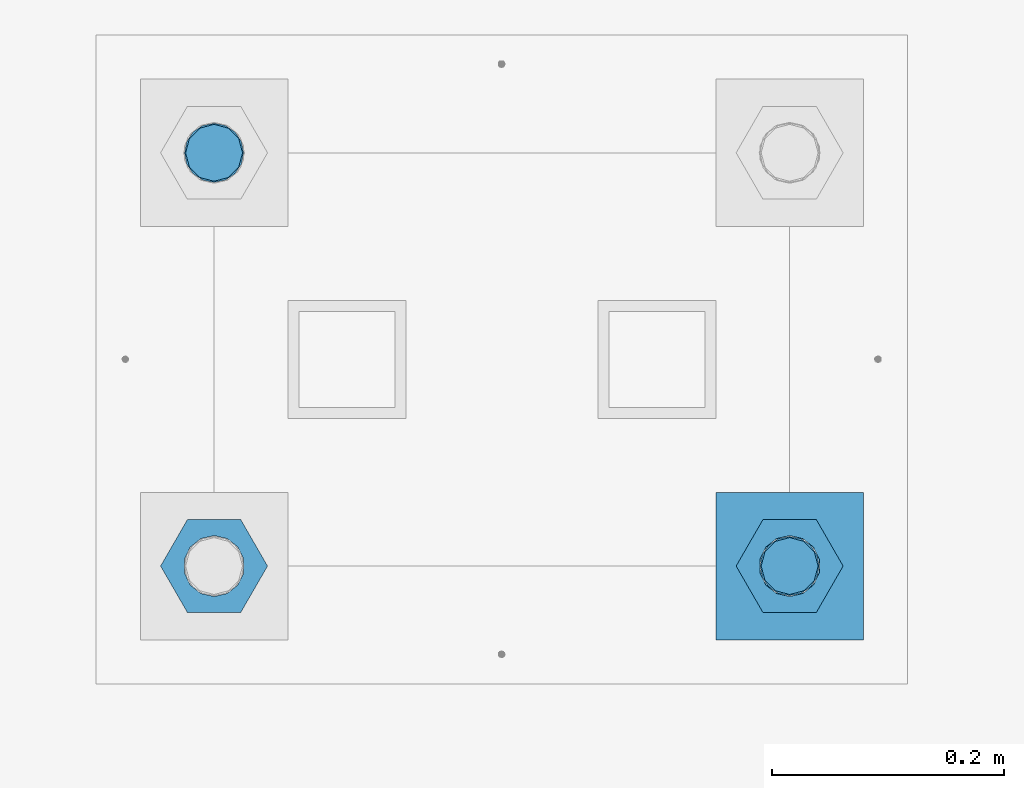
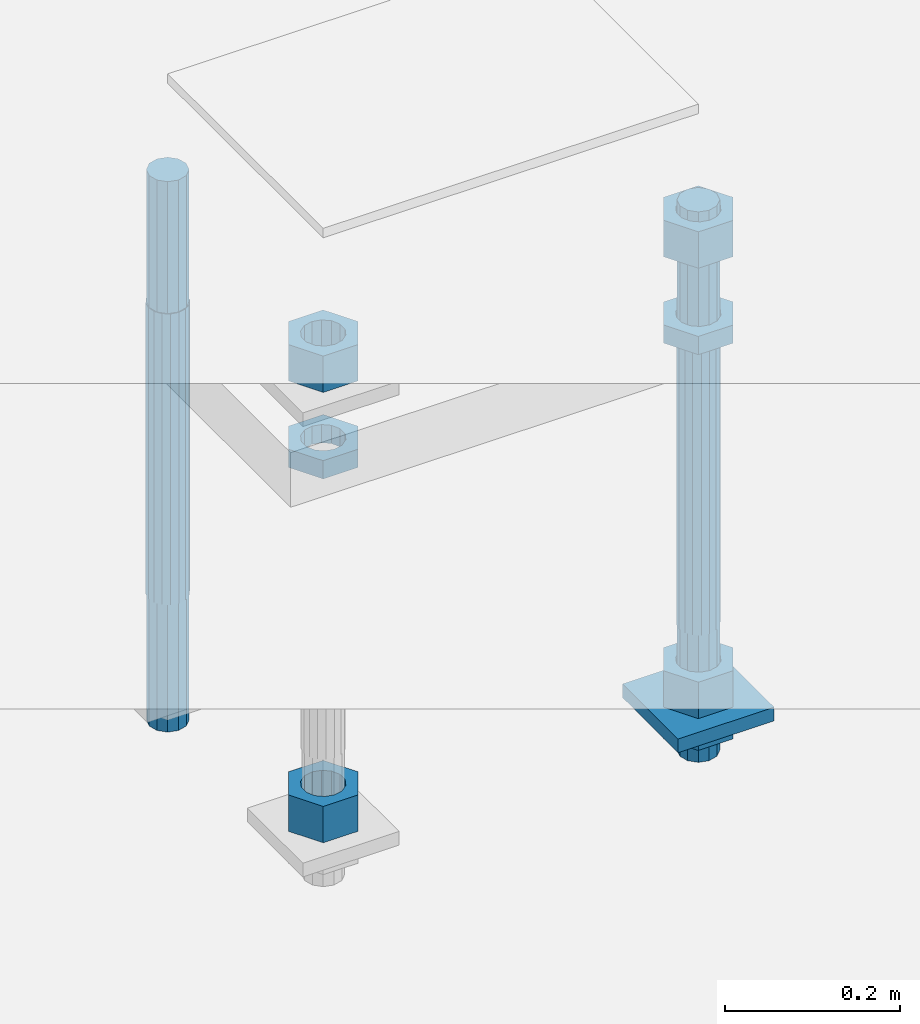
# One storey, part 2571 of 3843: 10 beams, 1 element without a shape of its own.
"""IFC2X3 building model written with IfcOpenShell, lengths in millimetres."""

from ifc_helpers import new_model, si_unit, frame, origin_with_axes, place, context, subcontext, project, spatial, faceted_brep, material, type_object, element, aggregate, save


model = new_model("IFC2X3")

# Units and contexts
model_context = context("Model", 3, precision=1e-05, world=origin_with_axes())
body_context = subcontext(model_context, "Body", "Model", "MODEL_VIEW")
ifc_project = project(units=[si_unit("LENGTHUNIT", "METRE", prefix="MILLI"), si_unit("AREAUNIT", "SQUARE_METRE"), si_unit("VOLUMEUNIT", "CUBIC_METRE"), si_unit("MASSUNIT", "GRAM", prefix="KILO"), si_unit("TIMEUNIT", "SECOND"), si_unit("PLANEANGLEUNIT", "RADIAN"), si_unit("SOLIDANGLEUNIT", "STERADIAN"), si_unit("THERMODYNAMICTEMPERATUREUNIT", "DEGREE_CELSIUS"), si_unit("LUMINOUSINTENSITYUNIT", "LUMEN")], contexts=[model_context])

# Site, building, storey
site_placement = place(None, origin_with_axes())
site = spatial("IfcSite", under=ifc_project, at=site_placement, CompositionType="ELEMENT")
building_placement = place(site_placement, origin_with_axes())
building = spatial("IfcBuilding", under=site, at=building_placement, Name="Undefined", CompositionType="ELEMENT")
storey_placement = place(building_placement, origin_with_axes())
storey = spatial("IfcBuildingStorey", under=building, at=storey_placement, Name="Undefined", CompositionType="ELEMENT", Elevation=0.0)

# Assembly, beams
assembly_placement = place(storey_placement, origin_with_axes())
assembly = element("IfcElementAssembly", 1, at=assembly_placement, inside=storey, Name="TEMPLATE", AssemblyPlace="NOTDEFINED", PredefinedType="RIGID_FRAME")
ifc_material_1 = material(Name="STEEL/A572-50")
beam_type_1 = type_object("IfcBeamType", PredefinedType="NOTDEFINED")
beam_1_placement = place(assembly_placement, frame((105403.65, 7442.19999847412, 29244.925), z_axis=(-1.0, 0.0, 0.0), x_axis=(0.0, -1.0, 0.0)))
beam_1 = element("IfcBeam", 2, at=beam_1_placement, type_object=beam_type_1, material=ifc_material_1, Name="WASHER_PLATE", context=body_context, shape_type="Brep", body=[
    faceted_brep([(0.0, 9.52500000000146, -63.5), (0.0, 9.52500000000146, 63.5), (127.0, 9.52500000000146, 63.5), (127.0, 9.52500000000146, -63.5), (0.0, -9.52500000000146, 63.5), (127.0, -9.52500000000146, 63.5), (0.0, -9.52500000000146, -63.5), (127.0, -9.52500000000146, -63.5)], [[[0, 1, 2, 3]], [[1, 4, 5, 2]], [[4, 6, 7, 5]], [[6, 0, 3, 7]], [[5, 7, 3, 2]], [[6, 4, 1, 0]]]),
])
ifc_material_2 = material(Name="STEEL/A36")
beam_type_2 = type_object("IfcBeamType", Name="2_HALF_NUT", PredefinedType="NOTDEFINED")
beam_2_placement = place(assembly_placement, frame((105403.65, 7378.69999847412, 29787.85), z_axis=(0.0, -1.0, 0.0), x_axis=(0.0, 0.0, -1.0)))
beam_2 = element("IfcBeam", 3, at=beam_2_placement, type_object=beam_type_2, material=ifc_material_2, Name="NUT", ObjectType="2_HALF_NUT", context=body_context, shape_type="Brep", body=[
    faceted_brep([(0.0, -46.0369987487793, 0.0), (0.0, -23.0184993743896, -39.869213104248), (25.4000000000015, -23.0184993743896, -39.869213104248), (25.4000000000015, -46.0369987487793, 0.0), (0.0, 23.0184993743896, -39.869213104248), (25.4000000000015, 23.0184993743896, -39.869213104248), (0.0, 46.0369987487793, 0.0), (25.4000000000015, 46.0369987487793, 0.0), (0.0, 23.0184993743896, 39.869213104248), (25.4000000000015, 23.0184993743896, 39.869213104248), (0.0, -23.0184993743896, 39.869213104248), (25.4000000000015, -23.0184993743896, 39.869213104248), (0.0, 0.0, 26.1940002441406), (0.0, 11.3650617044477, 23.5999013092805), (25.4000000000015, 11.3650617044477, 23.5999013092805), (25.4000000000015, 0.0, 26.1940002441406), (0.0, 20.4791109456419, 16.3316083006721), (25.4000000000015, 20.4791109456419, 16.3316083006721), (0.0, 25.5370200498292, 5.82867859874386), (25.4000000000015, 25.5370200498292, 5.82867859874386), (0.0, 25.5370200498292, -5.82867859874386), (25.4000000000015, 25.5370200498292, -5.82867859874386), (0.0, 20.4791109456419, -16.3316083006721), (25.4000000000015, 20.4791109456419, -16.3316083006721), (0.0, 11.3650617044477, -23.5999013092805), (25.4000000000015, 11.3650617044477, -23.5999013092805), (0.0, 0.0, -26.1940002441406), (25.4000000000015, 0.0, -26.1940002441406), (0.0, -11.3650617044477, -23.5999013092805), (25.4000000000015, -11.3650617044477, -23.5999013092805), (0.0, -20.4791109456419, -16.3316083006721), (25.4000000000015, -20.4791109456419, -16.3316083006721), (0.0, -25.5370200498292, -5.82867859874386), (25.4000000000015, -25.5370200498292, -5.82867859874386), (0.0, -25.5370200498292, 5.82867859874386), (25.4000000000015, -25.5370200498292, 5.82867859874386), (0.0, -20.4791109456419, 16.3316083006721), (25.4000000000015, -20.4791109456419, 16.3316083006721), (0.0, -11.3650617044477, 23.5999013092805), (25.4000000000015, -11.3650617044477, 23.5999013092805)], [[[0, 1, 2, 3]], [[1, 4, 5, 2]], [[4, 6, 7, 5]], [[6, 8, 9, 7]], [[8, 10, 11, 9]], [[10, 0, 3, 11]], [[12, 13, 14, 15]], [[13, 16, 17, 14]], [[16, 18, 19, 17]], [[18, 20, 21, 19]], [[20, 22, 23, 21]], [[22, 24, 25, 23]], [[24, 26, 27, 25]], [[26, 28, 29, 27]], [[28, 30, 31, 29]], [[30, 32, 33, 31]], [[32, 34, 35, 33]], [[34, 36, 37, 35]], [[36, 38, 39, 37]], [[38, 12, 15, 39]], [[5, 7, 9, 11, 3, 2], [17, 19, 21, 23, 25, 27, 29, 31, 33, 35, 37, 39, 15, 14]], [[10, 8, 6, 4, 1, 0], [38, 36, 34, 32, 30, 28, 26, 24, 22, 20, 18, 16, 13, 12]]]),
])
beam_3_placement = place(assembly_placement, frame((105403.65, 7378.69999847412, 29235.4), z_axis=(0.0, -1.0, 0.0), x_axis=(0.0, 0.0, -1.0)))
beam_3 = element("IfcBeam", 4, at=beam_3_placement, type_object=beam_type_2, material=ifc_material_2, Name="NUT", ObjectType="2_HALF_NUT", context=body_context, shape_type="Brep", body=[
    faceted_brep([(0.0, -46.0369987487793, 0.0), (0.0, -23.0184993743896, -39.869213104248), (25.4000000000015, -23.0184993743896, -39.869213104248), (25.4000000000015, -46.0369987487793, 0.0), (0.0, 23.0184993743896, -39.869213104248), (25.4000000000015, 23.0184993743896, -39.869213104248), (0.0, 46.0369987487793, 0.0), (25.4000000000015, 46.0369987487793, 0.0), (0.0, 23.0184993743896, 39.869213104248), (25.4000000000015, 23.0184993743896, 39.869213104248), (0.0, -23.0184993743896, 39.869213104248), (25.4000000000015, -23.0184993743896, 39.869213104248), (0.0, 0.0, 26.1940002441406), (0.0, 11.3650617044477, 23.5999013092805), (25.4000000000015, 11.3650617044477, 23.5999013092805), (25.4000000000015, 0.0, 26.1940002441406), (0.0, 20.4791109456419, 16.3316083006721), (25.4000000000015, 20.4791109456419, 16.3316083006721), (0.0, 25.5370200498292, 5.82867859874386), (25.4000000000015, 25.5370200498292, 5.82867859874386), (0.0, 25.5370200498292, -5.82867859874386), (25.4000000000015, 25.5370200498292, -5.82867859874386), (0.0, 20.4791109456419, -16.3316083006721), (25.4000000000015, 20.4791109456419, -16.3316083006721), (0.0, 11.3650617044477, -23.5999013092805), (25.4000000000015, 11.3650617044477, -23.5999013092805), (0.0, 0.0, -26.1940002441406), (25.4000000000015, 0.0, -26.1940002441406), (0.0, -11.3650617044477, -23.5999013092805), (25.4000000000015, -11.3650617044477, -23.5999013092805), (0.0, -20.4791109456419, -16.3316083006721), (25.4000000000015, -20.4791109456419, -16.3316083006721), (0.0, -25.5370200498292, -5.82867859874386), (25.4000000000015, -25.5370200498292, -5.82867859874386), (0.0, -25.5370200498292, 5.82867859874386), (25.4000000000015, -25.5370200498292, 5.82867859874386), (0.0, -20.4791109456419, 16.3316083006721), (25.4000000000015, -20.4791109456419, 16.3316083006721), (0.0, -11.3650617044477, 23.5999013092805), (25.4000000000015, -11.3650617044477, 23.5999013092805)], [[[0, 1, 2, 3]], [[1, 4, 5, 2]], [[4, 6, 7, 5]], [[6, 8, 9, 7]], [[8, 10, 11, 9]], [[10, 0, 3, 11]], [[12, 13, 14, 15]], [[13, 16, 17, 14]], [[16, 18, 19, 17]], [[18, 20, 21, 19]], [[20, 22, 23, 21]], [[22, 24, 25, 23]], [[24, 26, 27, 25]], [[26, 28, 29, 27]], [[28, 30, 31, 29]], [[30, 32, 33, 31]], [[32, 34, 35, 33]], [[34, 36, 37, 35]], [[36, 38, 39, 37]], [[38, 12, 15, 39]], [[5, 7, 9, 11, 3, 2], [17, 19, 21, 23, 25, 27, 29, 31, 33, 35, 37, 39, 15, 14]], [[10, 8, 6, 4, 1, 0], [38, 36, 34, 32, 30, 28, 26, 24, 22, 20, 18, 16, 13, 12]]]),
])
beam_4_placement = place(assembly_placement, frame((104908.35, 7378.69999847412, 29787.85), z_axis=(0.0, -1.0, 0.0), x_axis=(0.0, 0.0, -1.0)))
beam_4 = element("IfcBeam", 5, at=beam_4_placement, type_object=beam_type_2, material=ifc_material_2, Name="NUT", ObjectType="2_HALF_NUT", context=body_context, shape_type="Brep", body=[
    faceted_brep([(0.0, -46.0369987487793, 0.0), (0.0, -23.0184993743896, -39.869213104248), (25.4000000000015, -23.0184993743896, -39.869213104248), (25.4000000000015, -46.0369987487793, 0.0), (0.0, 23.0184993743896, -39.869213104248), (25.4000000000015, 23.0184993743896, -39.869213104248), (0.0, 46.0369987487793, 0.0), (25.4000000000015, 46.0369987487793, 0.0), (0.0, 23.0184993743896, 39.869213104248), (25.4000000000015, 23.0184993743896, 39.869213104248), (0.0, -23.0184993743896, 39.869213104248), (25.4000000000015, -23.0184993743896, 39.869213104248), (0.0, 0.0, 26.1940002441406), (0.0, 11.3650617044477, 23.5999013092805), (25.4000000000015, 11.3650617044477, 23.5999013092805), (25.4000000000015, 0.0, 26.1940002441406), (0.0, 20.4791109456419, 16.3316083006721), (25.4000000000015, 20.4791109456419, 16.3316083006721), (0.0, 25.5370200498292, 5.82867859874386), (25.4000000000015, 25.5370200498292, 5.82867859874386), (0.0, 25.5370200498292, -5.82867859874386), (25.4000000000015, 25.5370200498292, -5.82867859874386), (0.0, 20.4791109456419, -16.3316083006721), (25.4000000000015, 20.4791109456419, -16.3316083006721), (0.0, 11.3650617044477, -23.5999013092805), (25.4000000000015, 11.3650617044477, -23.5999013092805), (0.0, 0.0, -26.1940002441406), (25.4000000000015, 0.0, -26.1940002441406), (0.0, -11.3650617044477, -23.5999013092805), (25.4000000000015, -11.3650617044477, -23.5999013092805), (0.0, -20.4791109456419, -16.3316083006721), (25.4000000000015, -20.4791109456419, -16.3316083006721), (0.0, -25.5370200498292, -5.82867859874386), (25.4000000000015, -25.5370200498292, -5.82867859874386), (0.0, -25.5370200498292, 5.82867859874386), (25.4000000000015, -25.5370200498292, 5.82867859874386), (0.0, -20.4791109456419, 16.3316083006721), (25.4000000000015, -20.4791109456419, 16.3316083006721), (0.0, -11.3650617044477, 23.5999013092805), (25.4000000000015, -11.3650617044477, 23.5999013092805)], [[[0, 1, 2, 3]], [[1, 4, 5, 2]], [[4, 6, 7, 5]], [[6, 8, 9, 7]], [[8, 10, 11, 9]], [[10, 0, 3, 11]], [[12, 13, 14, 15]], [[13, 16, 17, 14]], [[16, 18, 19, 17]], [[18, 20, 21, 19]], [[20, 22, 23, 21]], [[22, 24, 25, 23]], [[24, 26, 27, 25]], [[26, 28, 29, 27]], [[28, 30, 31, 29]], [[30, 32, 33, 31]], [[32, 34, 35, 33]], [[34, 36, 37, 35]], [[36, 38, 39, 37]], [[38, 12, 15, 39]], [[5, 7, 9, 11, 3, 2], [17, 19, 21, 23, 25, 27, 29, 31, 33, 35, 37, 39, 15, 14]], [[10, 8, 6, 4, 1, 0], [38, 36, 34, 32, 30, 28, 26, 24, 22, 20, 18, 16, 13, 12]]]),
])
beam_type_3 = type_object("IfcBeamType", Name="2_HEAVY_HEX_NUT", PredefinedType="NOTDEFINED")
beam_5_placement = place(assembly_placement, frame((105403.65, 7378.69999847412, 29933.9), z_axis=(0.0, -1.0, 0.0), x_axis=(0.0, 0.0, -1.0)))
beam_5 = element("IfcBeam", 6, at=beam_5_placement, type_object=beam_type_3, material=ifc_material_2, Name="NUT", ObjectType="2_HEAVY_HEX_NUT", context=body_context, shape_type="Brep", body=[
    faceted_brep([(0.0, -46.0369987487793, 0.0), (0.0, -23.0184993743896, -39.869213104248), (50.7999999999993, -23.0184993743896, -39.869213104248), (50.7999999999993, -46.0369987487793, 0.0), (0.0, 23.0184993743896, -39.869213104248), (50.7999999999993, 23.0184993743896, -39.869213104248), (0.0, 46.0369987487793, 0.0), (50.7999999999993, 46.0369987487793, 0.0), (0.0, 23.0184993743896, 39.869213104248), (50.7999999999993, 23.0184993743896, 39.869213104248), (0.0, -23.0184993743896, 39.869213104248), (50.7999999999993, -23.0184993743896, 39.869213104248), (0.0, 0.0, 26.1940002441406), (0.0, 11.3650617044477, 23.5999013092805), (50.7999999999993, 11.3650617044477, 23.5999013092805), (50.7999999999993, 0.0, 26.1940002441406), (0.0, 20.4791109456419, 16.3316083006721), (50.7999999999993, 20.4791109456419, 16.3316083006721), (0.0, 25.5370200498292, 5.82867859874386), (50.7999999999993, 25.5370200498292, 5.82867859874386), (0.0, 25.5370200498292, -5.82867859874386), (50.7999999999993, 25.5370200498292, -5.82867859874386), (0.0, 20.4791109456419, -16.3316083006721), (50.7999999999993, 20.4791109456419, -16.3316083006721), (0.0, 11.3650617044477, -23.5999013092805), (50.7999999999993, 11.3650617044477, -23.5999013092805), (0.0, 0.0, -26.1940002441406), (50.7999999999993, 0.0, -26.1940002441406), (0.0, -11.3650617044477, -23.5999013092805), (50.7999999999993, -11.3650617044477, -23.5999013092805), (0.0, -20.4791109456419, -16.3316083006721), (50.7999999999993, -20.4791109456419, -16.3316083006721), (0.0, -25.5370200498292, -5.82867859874386), (50.7999999999993, -25.5370200498292, -5.82867859874386), (0.0, -25.5370200498292, 5.82867859874386), (50.7999999999993, -25.5370200498292, 5.82867859874386), (0.0, -20.4791109456419, 16.3316083006721), (50.7999999999993, -20.4791109456419, 16.3316083006721), (0.0, -11.3650617044477, 23.5999013092805), (50.7999999999993, -11.3650617044477, 23.5999013092805)], [[[0, 1, 2, 3]], [[1, 4, 5, 2]], [[4, 6, 7, 5]], [[6, 8, 9, 7]], [[8, 10, 11, 9]], [[10, 0, 3, 11]], [[12, 13, 14, 15]], [[13, 16, 17, 14]], [[16, 18, 19, 17]], [[18, 20, 21, 19]], [[20, 22, 23, 21]], [[22, 24, 25, 23]], [[24, 26, 27, 25]], [[26, 28, 29, 27]], [[28, 30, 31, 29]], [[30, 32, 33, 31]], [[32, 34, 35, 33]], [[34, 36, 37, 35]], [[36, 38, 39, 37]], [[38, 12, 15, 39]], [[5, 7, 9, 11, 3, 2], [17, 19, 21, 23, 25, 27, 29, 31, 33, 35, 37, 39, 15, 14]], [[10, 8, 6, 4, 1, 0], [38, 36, 34, 32, 30, 28, 26, 24, 22, 20, 18, 16, 13, 12]]]),
])
beam_6_placement = place(assembly_placement, frame((105403.65, 7378.69999847412, 29305.25), z_axis=(0.0, -1.0, 0.0), x_axis=(0.0, 0.0, -1.0)))
beam_6 = element("IfcBeam", 7, at=beam_6_placement, type_object=beam_type_3, material=ifc_material_2, Name="NUT", ObjectType="2_HEAVY_HEX_NUT", context=body_context, shape_type="Brep", body=[
    faceted_brep([(0.0, -46.0369987487793, 0.0), (0.0, -23.0184993743896, -39.869213104248), (50.7999999999993, -23.0184993743896, -39.869213104248), (50.7999999999993, -46.0369987487793, 0.0), (0.0, 23.0184993743896, -39.869213104248), (50.7999999999993, 23.0184993743896, -39.869213104248), (0.0, 46.0369987487793, 0.0), (50.7999999999993, 46.0369987487793, 0.0), (0.0, 23.0184993743896, 39.869213104248), (50.7999999999993, 23.0184993743896, 39.869213104248), (0.0, -23.0184993743896, 39.869213104248), (50.7999999999993, -23.0184993743896, 39.869213104248), (0.0, 0.0, 26.1940002441406), (0.0, 11.3650617044477, 23.5999013092805), (50.7999999999993, 11.3650617044477, 23.5999013092805), (50.7999999999993, 0.0, 26.1940002441406), (0.0, 20.4791109456419, 16.3316083006721), (50.7999999999993, 20.4791109456419, 16.3316083006721), (0.0, 25.5370200498292, 5.82867859874386), (50.7999999999993, 25.5370200498292, 5.82867859874386), (0.0, 25.5370200498292, -5.82867859874386), (50.7999999999993, 25.5370200498292, -5.82867859874386), (0.0, 20.4791109456419, -16.3316083006721), (50.7999999999993, 20.4791109456419, -16.3316083006721), (0.0, 11.3650617044477, -23.5999013092805), (50.7999999999993, 11.3650617044477, -23.5999013092805), (0.0, 0.0, -26.1940002441406), (50.7999999999993, 0.0, -26.1940002441406), (0.0, -11.3650617044477, -23.5999013092805), (50.7999999999993, -11.3650617044477, -23.5999013092805), (0.0, -20.4791109456419, -16.3316083006721), (50.7999999999993, -20.4791109456419, -16.3316083006721), (0.0, -25.5370200498292, -5.82867859874386), (50.7999999999993, -25.5370200498292, -5.82867859874386), (0.0, -25.5370200498292, 5.82867859874386), (50.7999999999993, -25.5370200498292, 5.82867859874386), (0.0, -20.4791109456419, 16.3316083006721), (50.7999999999993, -20.4791109456419, 16.3316083006721), (0.0, -11.3650617044477, 23.5999013092805), (50.7999999999993, -11.3650617044477, 23.5999013092805)], [[[0, 1, 2, 3]], [[1, 4, 5, 2]], [[4, 6, 7, 5]], [[6, 8, 9, 7]], [[8, 10, 11, 9]], [[10, 0, 3, 11]], [[12, 13, 14, 15]], [[13, 16, 17, 14]], [[16, 18, 19, 17]], [[18, 20, 21, 19]], [[20, 22, 23, 21]], [[22, 24, 25, 23]], [[24, 26, 27, 25]], [[26, 28, 29, 27]], [[28, 30, 31, 29]], [[30, 32, 33, 31]], [[32, 34, 35, 33]], [[34, 36, 37, 35]], [[36, 38, 39, 37]], [[38, 12, 15, 39]], [[5, 7, 9, 11, 3, 2], [17, 19, 21, 23, 25, 27, 29, 31, 33, 35, 37, 39, 15, 14]], [[10, 8, 6, 4, 1, 0], [38, 36, 34, 32, 30, 28, 26, 24, 22, 20, 18, 16, 13, 12]]]),
])
beam_7_placement = place(assembly_placement, frame((104908.35, 7378.69999847412, 29933.9), z_axis=(0.0, -1.0, 0.0), x_axis=(0.0, 0.0, -1.0)))
beam_7 = element("IfcBeam", 8, at=beam_7_placement, type_object=beam_type_3, material=ifc_material_2, Name="NUT", ObjectType="2_HEAVY_HEX_NUT", context=body_context, shape_type="Brep", body=[
    faceted_brep([(0.0, -46.0369987487793, 0.0), (0.0, -23.0184993743896, -39.869213104248), (50.7999999999993, -23.0184993743896, -39.869213104248), (50.7999999999993, -46.0369987487793, 0.0), (0.0, 23.0184993743896, -39.869213104248), (50.7999999999993, 23.0184993743896, -39.869213104248), (0.0, 46.0369987487793, 0.0), (50.7999999999993, 46.0369987487793, 0.0), (0.0, 23.0184993743896, 39.869213104248), (50.7999999999993, 23.0184993743896, 39.869213104248), (0.0, -23.0184993743896, 39.869213104248), (50.7999999999993, -23.0184993743896, 39.869213104248), (0.0, 0.0, 26.1940002441406), (0.0, 11.3650617044477, 23.5999013092805), (50.7999999999993, 11.3650617044477, 23.5999013092805), (50.7999999999993, 0.0, 26.1940002441406), (0.0, 20.4791109456419, 16.3316083006721), (50.7999999999993, 20.4791109456419, 16.3316083006721), (0.0, 25.5370200498292, 5.82867859874386), (50.7999999999993, 25.5370200498292, 5.82867859874386), (0.0, 25.5370200498292, -5.82867859874386), (50.7999999999993, 25.5370200498292, -5.82867859874386), (0.0, 20.4791109456419, -16.3316083006721), (50.7999999999993, 20.4791109456419, -16.3316083006721), (0.0, 11.3650617044477, -23.5999013092805), (50.7999999999993, 11.3650617044477, -23.5999013092805), (0.0, 0.0, -26.1940002441406), (50.7999999999993, 0.0, -26.1940002441406), (0.0, -11.3650617044477, -23.5999013092805), (50.7999999999993, -11.3650617044477, -23.5999013092805), (0.0, -20.4791109456419, -16.3316083006721), (50.7999999999993, -20.4791109456419, -16.3316083006721), (0.0, -25.5370200498292, -5.82867859874386), (50.7999999999993, -25.5370200498292, -5.82867859874386), (0.0, -25.5370200498292, 5.82867859874386), (50.7999999999993, -25.5370200498292, 5.82867859874386), (0.0, -20.4791109456419, 16.3316083006721), (50.7999999999993, -20.4791109456419, 16.3316083006721), (0.0, -11.3650617044477, 23.5999013092805), (50.7999999999993, -11.3650617044477, 23.5999013092805)], [[[0, 1, 2, 3]], [[1, 4, 5, 2]], [[4, 6, 7, 5]], [[6, 8, 9, 7]], [[8, 10, 11, 9]], [[10, 0, 3, 11]], [[12, 13, 14, 15]], [[13, 16, 17, 14]], [[16, 18, 19, 17]], [[18, 20, 21, 19]], [[20, 22, 23, 21]], [[22, 24, 25, 23]], [[24, 26, 27, 25]], [[26, 28, 29, 27]], [[28, 30, 31, 29]], [[30, 32, 33, 31]], [[32, 34, 35, 33]], [[34, 36, 37, 35]], [[36, 38, 39, 37]], [[38, 12, 15, 39]], [[5, 7, 9, 11, 3, 2], [17, 19, 21, 23, 25, 27, 29, 31, 33, 35, 37, 39, 15, 14]], [[10, 8, 6, 4, 1, 0], [38, 36, 34, 32, 30, 28, 26, 24, 22, 20, 18, 16, 13, 12]]]),
])
beam_8_placement = place(assembly_placement, frame((104908.35, 7378.69999847412, 29305.25), z_axis=(0.0, -1.0, 0.0), x_axis=(0.0, 0.0, -1.0)))
beam_8 = element("IfcBeam", 9, at=beam_8_placement, type_object=beam_type_3, material=ifc_material_2, Name="NUT", ObjectType="2_HEAVY_HEX_NUT", context=body_context, shape_type="Brep", body=[
    faceted_brep([(0.0, -46.0369987487793, 0.0), (0.0, -23.0184993743896, -39.869213104248), (50.7999999999993, -23.0184993743896, -39.869213104248), (50.7999999999993, -46.0369987487793, 0.0), (0.0, 23.0184993743896, -39.869213104248), (50.7999999999993, 23.0184993743896, -39.869213104248), (0.0, 46.0369987487793, 0.0), (50.7999999999993, 46.0369987487793, 0.0), (0.0, 23.0184993743896, 39.869213104248), (50.7999999999993, 23.0184993743896, 39.869213104248), (0.0, -23.0184993743896, 39.869213104248), (50.7999999999993, -23.0184993743896, 39.869213104248), (0.0, 0.0, 26.1940002441406), (0.0, 11.3650617044477, 23.5999013092805), (50.7999999999993, 11.3650617044477, 23.5999013092805), (50.7999999999993, 0.0, 26.1940002441406), (0.0, 20.4791109456419, 16.3316083006721), (50.7999999999993, 20.4791109456419, 16.3316083006721), (0.0, 25.5370200498292, 5.82867859874386), (50.7999999999993, 25.5370200498292, 5.82867859874386), (0.0, 25.5370200498292, -5.82867859874386), (50.7999999999993, 25.5370200498292, -5.82867859874386), (0.0, 20.4791109456419, -16.3316083006721), (50.7999999999993, 20.4791109456419, -16.3316083006721), (0.0, 11.3650617044477, -23.5999013092805), (50.7999999999993, 11.3650617044477, -23.5999013092805), (0.0, 0.0, -26.1940002441406), (50.7999999999993, 0.0, -26.1940002441406), (0.0, -11.3650617044477, -23.5999013092805), (50.7999999999993, -11.3650617044477, -23.5999013092805), (0.0, -20.4791109456419, -16.3316083006721), (50.7999999999993, -20.4791109456419, -16.3316083006721), (0.0, -25.5370200498292, -5.82867859874386), (50.7999999999993, -25.5370200498292, -5.82867859874386), (0.0, -25.5370200498292, 5.82867859874386), (50.7999999999993, -25.5370200498292, 5.82867859874386), (0.0, -20.4791109456419, 16.3316083006721), (50.7999999999993, -20.4791109456419, 16.3316083006721), (0.0, -11.3650617044477, 23.5999013092805), (50.7999999999993, -11.3650617044477, 23.5999013092805)], [[[0, 1, 2, 3]], [[1, 4, 5, 2]], [[4, 6, 7, 5]], [[6, 8, 9, 7]], [[8, 10, 11, 9]], [[10, 0, 3, 11]], [[12, 13, 14, 15]], [[13, 16, 17, 14]], [[16, 18, 19, 17]], [[18, 20, 21, 19]], [[20, 22, 23, 21]], [[22, 24, 25, 23]], [[24, 26, 27, 25]], [[26, 28, 29, 27]], [[28, 30, 31, 29]], [[30, 32, 33, 31]], [[32, 34, 35, 33]], [[34, 36, 37, 35]], [[36, 38, 39, 37]], [[38, 12, 15, 39]], [[5, 7, 9, 11, 3, 2], [17, 19, 21, 23, 25, 27, 29, 31, 33, 35, 37, 39, 15, 14]], [[10, 8, 6, 4, 1, 0], [38, 36, 34, 32, 30, 28, 26, 24, 22, 20, 18, 16, 13, 12]]]),
])
ifc_material_3 = material()
beam_type_4 = type_object("IfcBeamType", PredefinedType="NOTDEFINED")
beam_9_placement = place(assembly_placement, frame((104908.35, 7734.29999847413, 29762.45), z_axis=(0.0, -1.0, 0.0), x_axis=(0.0, 0.0, -1.0)))
beam_9 = element("IfcBeam", 10, at=beam_9_placement, type_object=beam_type_4, material=ifc_material_3, Name="ANCHOR_ROD", context=body_context, shape_type="Brep", body=[
    faceted_brep([(-184.150000000001, -21.217622392709, 12.25), (-184.150000000001, -12.2499999999854, 21.2176223927163), (-184.150000000001, 1.45519152283669e-11, 24.5), (-184.150000000001, 12.2500000000146, 21.2176223927163), (-184.150000000001, 21.2176223927381, 12.25), (-184.150000000001, 24.5000000000146, 0.0), (-184.150000000001, 21.2176223927381, -12.25), (-184.150000000001, 12.2500000000146, -21.2176223927163), (-184.150000000001, 1.45519152283669e-11, -24.5), (-184.150000000001, -12.2499999999854, -21.2176223927163), (-184.150000000001, -21.217622392709, -12.25), (-184.150000000001, -24.4999999999854, 0.0), (0.0, 24.5000000000146, 0.0), (0.0, 21.2176223927381, -12.25), (0.0, 12.2500000000146, -21.2176223927163), (0.0, 1.45519152283669e-11, -24.5), (0.0, -12.2499999999854, -21.2176223927163), (0.0, -21.217622392709, -12.25), (0.0, -24.4999999999854, 0.0), (0.0, -21.217622392709, 12.25), (0.0, -12.2499999999854, 21.2176223927163), (0.0, 1.45519152283669e-11, 24.5), (0.0, 12.2500000000146, 21.2176223927163), (0.0, 21.2176223927381, 12.25), (0.0, -23.4665401257807, 9.72015918207035), (0.0, -17.9605122421344, 17.9605122421417), (0.0, -9.72015918207762, 23.466540125788), (0.0, 0.0, 25.4000000000015), (0.0, 9.72015918207762, 23.466540125788), (0.0, 17.9605122421344, 17.9605122421417), (0.0, 23.4665401257807, 9.72015918207035), (0.0, 25.3999996185303, 0.0), (0.0, 23.4665401257807, -9.72015918207035), (0.0, 17.9605122421344, -17.9605122421417), (0.0, 9.72015918207762, -23.466540125788), (0.0, 0.0, -25.4000000000015), (0.0, -9.72015918207762, -23.466540125788), (0.0, -17.9605122421344, -17.9605122421417), (0.0, -23.4665401257807, -9.72015918207035), (0.0, -25.3999996185303, 0.0), (406.399999999998, -25.3999999999942, 0.0), (406.399999999998, -23.4665401257807, 9.72015918207035), (406.399999999998, -17.9605122421344, 17.9605122421417), (406.399999999998, -9.72015918207762, 23.466540125788), (406.399999999998, 0.0, 25.4000000000015), (406.399999999998, 9.72015918207762, 23.466540125788), (406.399999999998, 17.9605122421344, 17.9605122421417), (406.399999999998, 23.4665401257807, 9.72015918207035), (406.399999999998, 25.3999999999942, 0.0), (406.399999999998, 23.4665401257807, -9.72015918207035), (406.399999999998, 17.9605122421344, -17.9605122421417), (406.399999999998, 9.72015918207762, -23.466540125788), (406.399999999998, 0.0, -25.4000000000015), (406.399999999998, -9.72015918207762, -23.466540125788), (406.399999999998, -17.9605122421344, -17.9605122421417), (406.399999999998, -23.4665401257807, -9.72015918207035), (406.399999999998, -12.2499999999854, 21.2176223927163), (406.399999999998, 1.45519152283669e-11, 24.5), (406.399999999998, 12.2500000000146, 21.2176223927163), (406.399999999998, 21.2176223927381, 12.25), (406.399999999998, 24.5000000000146, 0.0), (406.399999999998, 21.2176223927381, -12.25), (406.399999999998, 12.2500000000146, -21.2176223927163), (406.399999999998, 1.45519152283669e-11, -24.5), (406.399999999998, -12.2499999999854, -21.2176223927163), (406.399999999998, -21.217622392709, -12.25), (406.399999999998, -24.4999999999854, 0.0), (406.399999999998, -21.217622392709, 12.25), (584.200000000001, -12.2499999999854, -21.2176223927163), (584.200000000001, 1.45519152283669e-11, -24.5), (584.200000000001, 12.2500000000146, -21.2176223927163), (584.200000000001, 21.2176223927381, -12.25), (584.200000000001, 24.5000000000146, 0.0), (584.200000000001, 21.2176223927381, 12.25), (584.200000000001, 12.2500000000146, 21.2176223927163), (584.200000000001, 1.45519152283669e-11, 24.5), (584.200000000001, -12.2499999999854, 21.2176223927163), (584.200000000001, -21.217622392709, 12.25), (584.200000000001, -24.4999999999854, 0.0), (584.200000000001, -21.217622392709, -12.25)], [[[0, 1, 2, 3, 4, 5, 6, 7, 8, 9, 10, 11]], [[6, 5, 12, 13]], [[7, 6, 13, 14]], [[8, 7, 14, 15]], [[9, 8, 15, 16]], [[10, 9, 16, 17]], [[11, 10, 17, 18]], [[0, 11, 18, 19]], [[1, 0, 19, 20]], [[2, 1, 20, 21]], [[3, 2, 21, 22]], [[4, 3, 22, 23]], [[5, 4, 23, 12]], [[24, 25, 26, 27, 28, 29, 30, 31, 32, 33, 34, 35, 36, 37, 38, 39], [22, 21, 20, 19, 18, 17, 16, 15, 14, 13, 12, 23]], [[24, 39, 40, 41]], [[25, 24, 41, 42]], [[26, 25, 42, 43]], [[27, 26, 43, 44]], [[28, 27, 44, 45]], [[29, 28, 45, 46]], [[30, 29, 46, 47]], [[31, 30, 47, 48]], [[32, 31, 48, 49]], [[33, 32, 49, 50]], [[34, 33, 50, 51]], [[35, 34, 51, 52]], [[36, 35, 52, 53]], [[37, 36, 53, 54]], [[38, 37, 54, 55]], [[39, 38, 55, 40]], [[54, 53, 52, 51, 50, 49, 48, 47, 46, 45, 44, 43, 42, 41, 40, 55], [56, 57, 58, 59, 60, 61, 62, 63, 64, 65, 66, 67]], [[68, 69, 70, 71, 72, 73, 74, 75, 76, 77, 78, 79]], [[76, 75, 57, 56]], [[77, 76, 56, 67]], [[78, 77, 67, 66]], [[79, 78, 66, 65]], [[68, 79, 65, 64]], [[69, 68, 64, 63]], [[70, 69, 63, 62]], [[71, 70, 62, 61]], [[72, 71, 61, 60]], [[73, 72, 60, 59]], [[74, 73, 59, 58]], [[75, 74, 58, 57]]]),
])
beam_10_placement = place(assembly_placement, frame((105403.65, 7378.69999847412, 29762.45), z_axis=(0.0, -1.0, 0.0), x_axis=(0.0, 0.0, -1.0)))
beam_10 = element("IfcBeam", 11, at=beam_10_placement, type_object=beam_type_4, material=ifc_material_3, Name="ANCHOR_ROD", context=body_context, shape_type="Brep", body=[
    faceted_brep([(-184.150000000001, -21.217622392709, 12.25), (-184.150000000001, -12.2499999999854, 21.2176223927163), (-184.150000000001, 1.45519152283669e-11, 24.5), (-184.150000000001, 12.2500000000146, 21.2176223927163), (-184.150000000001, 21.2176223927381, 12.25), (-184.150000000001, 24.5000000000146, 0.0), (-184.150000000001, 21.2176223927381, -12.25), (-184.150000000001, 12.2500000000146, -21.2176223927163), (-184.150000000001, 1.45519152283669e-11, -24.5), (-184.150000000001, -12.2499999999854, -21.2176223927163), (-184.150000000001, -21.217622392709, -12.25), (-184.150000000001, -24.4999999999854, 0.0), (0.0, 24.5000000000146, 0.0), (0.0, 21.2176223927381, -12.25), (0.0, 12.2500000000146, -21.2176223927163), (0.0, 1.45519152283669e-11, -24.5), (0.0, -12.2499999999854, -21.2176223927163), (0.0, -21.217622392709, -12.25), (0.0, -24.4999999999854, 0.0), (0.0, -21.217622392709, 12.25), (0.0, -12.2499999999854, 21.2176223927163), (0.0, 1.45519152283669e-11, 24.5), (0.0, 12.2500000000146, 21.2176223927163), (0.0, 21.2176223927381, 12.25), (0.0, -23.4665401257807, 9.72015918207035), (0.0, -17.9605122421344, 17.9605122421417), (0.0, -9.72015918207762, 23.466540125788), (0.0, 0.0, 25.4000000000015), (0.0, 9.72015918207762, 23.466540125788), (0.0, 17.9605122421344, 17.9605122421417), (0.0, 23.4665401257807, 9.72015918207035), (0.0, 25.3999996185303, 0.0), (0.0, 23.4665401257807, -9.72015918207035), (0.0, 17.9605122421344, -17.9605122421417), (0.0, 9.72015918207762, -23.466540125788), (0.0, 0.0, -25.4000000000015), (0.0, -9.72015918207762, -23.466540125788), (0.0, -17.9605122421344, -17.9605122421417), (0.0, -23.4665401257807, -9.72015918207035), (0.0, -25.3999996185303, 0.0), (406.399999999998, -25.3999999999942, 0.0), (406.399999999998, -23.4665401257807, 9.72015918207035), (406.399999999998, -17.9605122421344, 17.9605122421417), (406.399999999998, -9.72015918207762, 23.466540125788), (406.399999999998, 0.0, 25.4000000000015), (406.399999999998, 9.72015918207762, 23.466540125788), (406.399999999998, 17.9605122421344, 17.9605122421417), (406.399999999998, 23.4665401257807, 9.72015918207035), (406.399999999998, 25.3999999999942, 0.0), (406.399999999998, 23.4665401257807, -9.72015918207035), (406.399999999998, 17.9605122421344, -17.9605122421417), (406.399999999998, 9.72015918207762, -23.466540125788), (406.399999999998, 0.0, -25.4000000000015), (406.399999999998, -9.72015918207762, -23.466540125788), (406.399999999998, -17.9605122421344, -17.9605122421417), (406.399999999998, -23.4665401257807, -9.72015918207035), (406.399999999998, -12.2499999999854, 21.2176223927163), (406.399999999998, 1.45519152283669e-11, 24.5), (406.399999999998, 12.2500000000146, 21.2176223927163), (406.399999999998, 21.2176223927381, 12.25), (406.399999999998, 24.5000000000146, 0.0), (406.399999999998, 21.2176223927381, -12.25), (406.399999999998, 12.2500000000146, -21.2176223927163), (406.399999999998, 1.45519152283669e-11, -24.5), (406.399999999998, -12.2499999999854, -21.2176223927163), (406.399999999998, -21.217622392709, -12.25), (406.399999999998, -24.4999999999854, 0.0), (406.399999999998, -21.217622392709, 12.25), (584.200000000001, -12.2499999999854, -21.2176223927163), (584.200000000001, 1.45519152283669e-11, -24.5), (584.200000000001, 12.2500000000146, -21.2176223927163), (584.200000000001, 21.2176223927381, -12.25), (584.200000000001, 24.5000000000146, 0.0), (584.200000000001, 21.2176223927381, 12.25), (584.200000000001, 12.2500000000146, 21.2176223927163), (584.200000000001, 1.45519152283669e-11, 24.5), (584.200000000001, -12.2499999999854, 21.2176223927163), (584.200000000001, -21.217622392709, 12.25), (584.200000000001, -24.4999999999854, 0.0), (584.200000000001, -21.217622392709, -12.25)], [[[0, 1, 2, 3, 4, 5, 6, 7, 8, 9, 10, 11]], [[6, 5, 12, 13]], [[7, 6, 13, 14]], [[8, 7, 14, 15]], [[9, 8, 15, 16]], [[10, 9, 16, 17]], [[11, 10, 17, 18]], [[0, 11, 18, 19]], [[1, 0, 19, 20]], [[2, 1, 20, 21]], [[3, 2, 21, 22]], [[4, 3, 22, 23]], [[5, 4, 23, 12]], [[24, 25, 26, 27, 28, 29, 30, 31, 32, 33, 34, 35, 36, 37, 38, 39], [22, 21, 20, 19, 18, 17, 16, 15, 14, 13, 12, 23]], [[24, 39, 40, 41]], [[25, 24, 41, 42]], [[26, 25, 42, 43]], [[27, 26, 43, 44]], [[28, 27, 44, 45]], [[29, 28, 45, 46]], [[30, 29, 46, 47]], [[31, 30, 47, 48]], [[32, 31, 48, 49]], [[33, 32, 49, 50]], [[34, 33, 50, 51]], [[35, 34, 51, 52]], [[36, 35, 52, 53]], [[37, 36, 53, 54]], [[38, 37, 54, 55]], [[39, 38, 55, 40]], [[54, 53, 52, 51, 50, 49, 48, 47, 46, 45, 44, 43, 42, 41, 40, 55], [56, 57, 58, 59, 60, 61, 62, 63, 64, 65, 66, 67]], [[68, 69, 70, 71, 72, 73, 74, 75, 76, 77, 78, 79]], [[76, 75, 57, 56]], [[77, 76, 56, 67]], [[78, 77, 67, 66]], [[79, 78, 66, 65]], [[68, 79, 65, 64]], [[69, 68, 64, 63]], [[70, 69, 63, 62]], [[71, 70, 62, 61]], [[72, 71, 61, 60]], [[73, 72, 60, 59]], [[74, 73, 59, 58]], [[75, 74, 58, 57]]]),
])
aggregate(assembly, [beam_9, beam_2, beam_5, beam_6, beam_3, beam_1, beam_10, beam_4, beam_7, beam_8])

save(model, "model.ifc")
